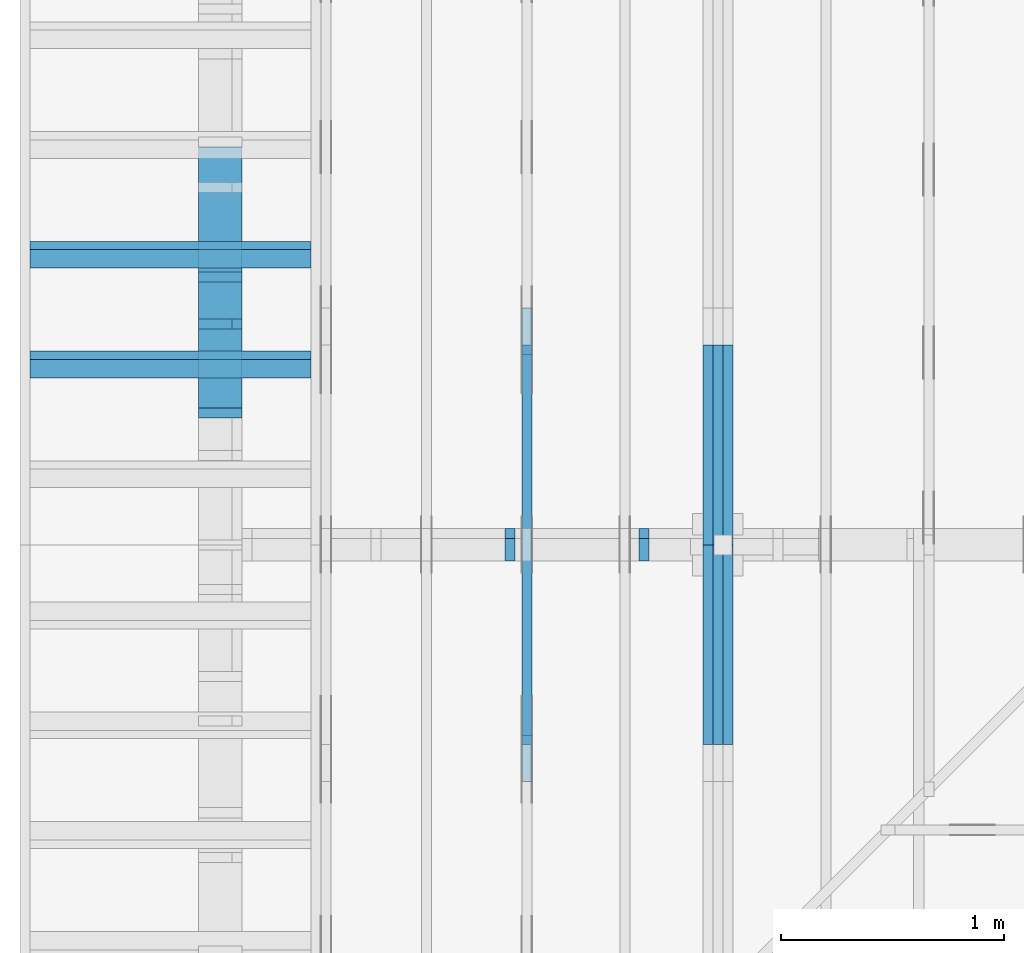
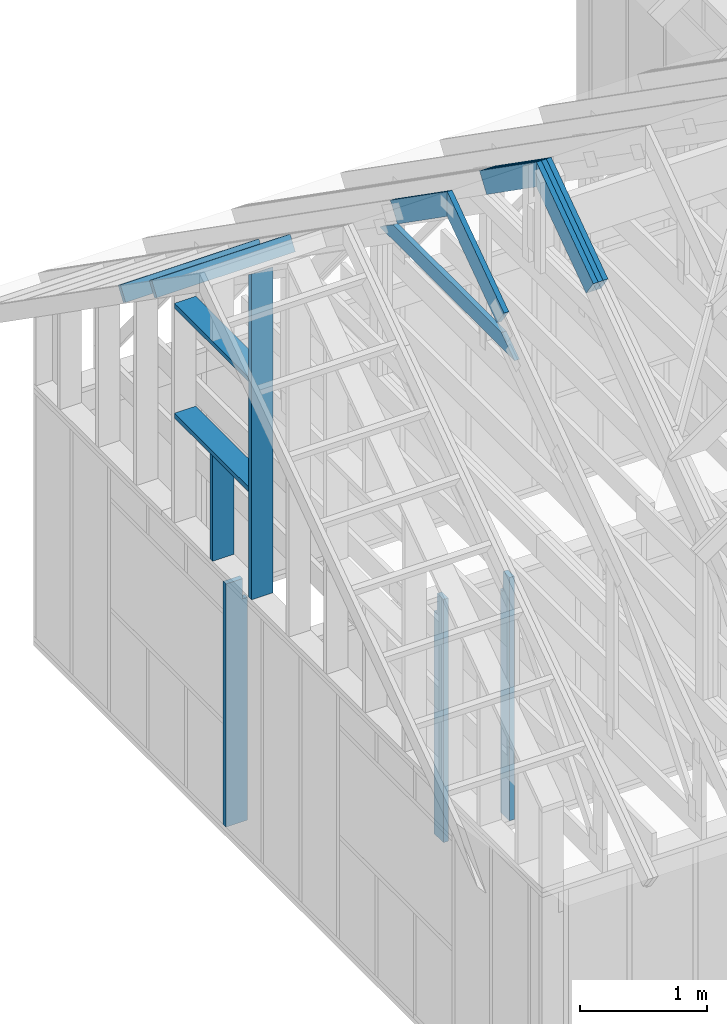
# One storey, part 11 of 70: 18 members, 6 elements without a shape of their own.
"""IFC2X3 building model written with IfcOpenShell, lengths in millimetres."""

from ifc_helpers import new_model, si_unit, frame, origin, origin_with_axes, origin_2d, place, context, project, spatial, faceted_brep, element, aggregate, save


model = new_model("IFC2X3")

# Units and contexts
model_context = context("Model", 3, precision=1e-05, world=origin())
plan_context = context("Plan", 2, precision=1e-05, world=origin_2d())
ifc_project = project(units=[si_unit("LENGTHUNIT", "METRE", prefix="MILLI"), si_unit("AREAUNIT", "SQUARE_METRE"), si_unit("VOLUMEUNIT", "CUBIC_METRE"), si_unit("SOLIDANGLEUNIT", "STERADIAN"), si_unit("PLANEANGLEUNIT", "RADIAN"), si_unit("MASSUNIT", "GRAM"), si_unit("TIMEUNIT", "SECOND"), si_unit("THERMODYNAMICTEMPERATUREUNIT", "DEGREE_CELSIUS"), si_unit("LUMINOUSINTENSITYUNIT", "LUMEN")], contexts=[model_context, plan_context])

# Site, building, storey
site_placement = place(None, origin_with_axes())
site = spatial("IfcSite", under=ifc_project, at=site_placement, CompositionType="ELEMENT")
building_placement = place(site_placement, origin_with_axes())
building = spatial("IfcBuilding", under=site, at=building_placement, Name="Layout 1", CompositionType="ELEMENT")
storey_placement = place(building_placement, origin_with_axes())
storey = spatial("IfcBuildingStorey", under=building, at=storey_placement, Name="Storey 1", CompositionType="ELEMENT", Elevation=0.0)

# Assembly, members
assembly_1_placement = place(storey_placement, frame((1969.9999999999982, 8000.000000000001, 1.1021457184401395e-14), z_axis=(-1.0, 1.836909530733566e-16, 6.123031769111886e-17), x_axis=(-1.836909530733566e-16, -1.0, 0.0)))
assembly_1 = element("IfcElementAssembly", 1, at=assembly_1_placement, inside=storey, Name="T11", AssemblyPlace="FACTORY", PredefinedType="TRUSS")
member_1_placement = place(assembly_1_placement, frame((3217.6903587327556, 3014.9999999980873, -90.0), z_axis=(0.0, 0.0, 1.0), x_axis=(0.8191520442889916, 0.5735764363510464, 0.0)))
member_1 = element("IfcMember", 2, at=member_1_placement, Name="T18", context=model_context, shape_type="Brep", body=[
    faceted_brep([(1091.564200553914, 195.00000000125283, 45.0), (0.0, 195.00000000125283, 45.0), (8.731149137020111e-11, 0.0, 45.0), (955.0237306050312, 0.0, 45.0), (0.0, 195.00000000125283, 0.0), (1091.564200553914, 195.00000000125283, 1.3367364556033665e-13), (955.0237306050312, 0.0, 1.1695281285500715e-13), (8.731149137020111e-11, 0.0, 1.0692220709365594e-26), (8.731149137020111e-11, 0.0, 0.0), (8.731424673449721e-11, 1.2330791498681715e-27, 45.0), (4.7951469120545665e-14, 195.000000002565, 45.0), (4.5196104824445316e-14, 195.000000002565, -2.7673718568020907e-30), (955.0237306050312, 4.127318893216278e-09, -1.955486371747768e-30), (955.0237306050312, 4.127321648580574e-09, 45.0), (8.73114913702011e-11, 2.7553642961032684e-15, 45.0), (8.731149137020111e-11, 2.9197490389586947e-27, -1.78777161234152e-43), (1091.564200553914, 195.00000000125283, 0.0), (1091.564200553914, 195.00000000125283, 45.0), (955.0237306050312, 4.127286956645548e-09, 45.0), (955.0237306050312, 4.127286956645548e-09, 0.0), (0.0, 195.000000002565, 0.0), (0.0, 195.000000002565, 45.0), (1091.564200553914, 195.00000000125272, 45.0), (1091.564200553914, 195.00000000125272, -6.310887241768095e-30)], [[[0, 1, 2, 3]], [[4, 5, 6, 7]], [[8, 9, 10, 11]], [[12, 13, 14, 15]], [[16, 17, 18, 19]], [[20, 21, 22, 23]]]),
])
member_2_placement = place(assembly_1_placement, frame((3217.6903587327556, 3014.9999999980873, -135.0), z_axis=(0.0, 0.0, 1.0), x_axis=(0.8191520442889916, 0.5735764363510464, 0.0)))
member_2 = element("IfcMember", 3, at=member_2_placement, Name="T18", context=model_context, shape_type="Brep", body=[
    faceted_brep([(1091.564200553914, 195.00000000125283, 45.0), (0.0, 195.00000000125283, 45.0), (8.731149137020111e-11, 0.0, 45.0), (955.0237306050312, 0.0, 45.0), (0.0, 195.00000000125283, 0.0), (1091.564200553914, 195.00000000125283, 1.3367364556033665e-13), (955.0237306050312, 0.0, 1.1695281285500715e-13), (8.731149137020111e-11, 0.0, 1.0692220709365594e-26), (8.731149137020111e-11, 0.0, 0.0), (8.731424673449721e-11, 1.2330791498681715e-27, 45.0), (4.7951469120545665e-14, 195.000000002565, 45.0), (4.5196104824445316e-14, 195.000000002565, -2.7673718568020907e-30), (955.0237306050312, 4.127318893216278e-09, -1.955486371747768e-30), (955.0237306050312, 4.127321648580574e-09, 45.0), (8.73114913702011e-11, 2.7553642961032684e-15, 45.0), (8.731149137020111e-11, 2.9197490389586947e-27, -1.78777161234152e-43), (1091.564200553914, 195.00000000125283, 0.0), (1091.564200553914, 195.00000000125283, 45.0), (955.0237306050312, 4.127286956645548e-09, 45.0), (955.0237306050312, 4.127286956645548e-09, 0.0), (0.0, 195.000000002565, 0.0), (0.0, 195.000000002565, 45.0), (1091.564200553914, 195.00000000125272, 45.0), (1091.564200553914, 195.00000000125272, -6.310887241768095e-30)], [[[0, 1, 2, 3]], [[4, 5, 6, 7]], [[8, 9, 10, 11]], [[12, 13, 14, 15]], [[16, 17, 18, 19]], [[20, 21, 22, 23]]]),
])
member_3_placement = place(assembly_1_placement, frame((3217.6903587327556, 3014.9999999980873, -180.0), z_axis=(0.0, 0.0, 1.0), x_axis=(0.8191520442889916, 0.5735764363510464, 0.0)))
member_3 = element("IfcMember", 4, at=member_3_placement, Name="T18", context=model_context, shape_type="Brep", body=[
    faceted_brep([(1091.564200553914, 195.00000000125283, 45.0), (0.0, 195.00000000125283, 45.0), (8.731149137020111e-11, 0.0, 45.0), (955.0237306050312, 0.0, 45.0), (0.0, 195.00000000125283, 0.0), (1091.564200553914, 195.00000000125283, 1.3367364556033665e-13), (955.0237306050312, 0.0, 1.1695281285500715e-13), (8.731149137020111e-11, 0.0, 1.0692220709365594e-26), (8.731149137020111e-11, 0.0, 0.0), (8.731424673449721e-11, 1.2330791498681715e-27, 45.0), (4.7951469120545665e-14, 195.000000002565, 45.0), (4.5196104824445316e-14, 195.000000002565, -2.7673718568020907e-30), (955.0237306050312, 4.127318893216278e-09, -1.955486371747768e-30), (955.0237306050312, 4.127321648580574e-09, 45.0), (8.73114913702011e-11, 2.7553642961032684e-15, 45.0), (8.731149137020111e-11, 2.9197490389586947e-27, -1.78777161234152e-43), (1091.564200553914, 195.00000000125283, 0.0), (1091.564200553914, 195.00000000125283, 45.0), (955.0237306050312, 4.127286956645548e-09, 45.0), (955.0237306050312, 4.127286956645548e-09, 0.0), (0.0, 195.000000002565, 0.0), (0.0, 195.000000002565, 45.0), (1091.564200553914, 195.00000000125272, 45.0), (1091.564200553914, 195.00000000125272, -6.310887241768095e-30)], [[[0, 1, 2, 3]], [[4, 5, 6, 7]], [[8, 9, 10, 11]], [[12, 13, 14, 15]], [[16, 17, 18, 19]], [[20, 21, 22, 23]]]),
])
member_4_placement = place(assembly_1_placement, frame((3888.1525949105694, 3641.0955042035366, -90.00000000000001), z_axis=(0.0, 0.0, 1.0), x_axis=(0.8191520442889916, -0.5735764363510465, 0.0)))
member_4 = element("IfcMember", 5, at=member_4_placement, Name="T18", context=model_context, shape_type="Brep", body=[
    faceted_brep([(1091.5642005560503, 194.99999999996362, 45.0), (0.0, 194.99999999996362, 45.0), (136.5404699520857, 0.0, 45.0), (1091.5642005561149, 0.0, 45.0), (0.0, 194.99999999996362, 0.0), (1091.5642005560503, 194.99999999996362, 1.336736455605983e-13), (1091.5642005561149, 0.0, 1.336736455606062e-13), (136.5404699520857, 0.0, 1.6720832705721752e-14), (136.54046995208566, -4.263256414560601e-14, 3.1554436208840472e-30), (136.54046995208566, -4.263256414560601e-14, 45.0), (1.4210854715202004e-14, 195.00000000170263, 45.0), (1.4210854715202004e-14, 195.00000000170263, -2.3665827156630354e-30), (1091.5642005561149, 2.0525182992035547e-09, 1.2934457505065866e-29), (1091.5642005561149, 2.0525210545678508e-09, 45.0), (136.5404699520857, -2.3668346958466476e-14, 45.0), (136.5404699520857, -2.6423711254566825e-14, 1.6179322346954286e-30), (1091.5642005561149, 194.99999999996362, 3.950615413346827e-27), (1091.5642005561149, 194.99999999996362, 45.0), (1091.5642005561149, 2.052729541901499e-09, 45.0), (1091.5642005561149, 2.052729541901499e-09, 0.0), (0.0, 195.00000000170257, 0.0), (0.0, 195.00000000170257, 45.0), (1091.5642005560503, 194.9999999999637, 45.0), (1091.5642005560503, 194.9999999999637, 6.310887241768095e-30)], [[[0, 1, 2, 3]], [[4, 5, 6, 7]], [[8, 9, 10, 11]], [[12, 13, 14, 15]], [[16, 17, 18, 19]], [[20, 21, 22, 23]]]),
])
member_5_placement = place(assembly_1_placement, frame((3888.1525949105694, 3641.0955042035366, -135.0), z_axis=(0.0, 0.0, 1.0), x_axis=(0.8191520442889916, -0.5735764363510465, 0.0)))
member_5 = element("IfcMember", 6, at=member_5_placement, Name="T18", context=model_context, shape_type="Brep", body=[
    faceted_brep([(1091.5642005560503, 194.99999999996362, 45.0), (0.0, 194.99999999996362, 45.0), (136.5404699520857, 0.0, 45.0), (1091.5642005561149, 0.0, 45.0), (0.0, 194.99999999996362, 0.0), (1091.5642005560503, 194.99999999996362, 1.336736455605983e-13), (1091.5642005561149, 0.0, 1.336736455606062e-13), (136.5404699520857, 0.0, 1.6720832705721752e-14), (136.54046995208566, -4.263256414560601e-14, 3.1554436208840472e-30), (136.54046995208566, -4.263256414560601e-14, 45.0), (1.4210854715202004e-14, 195.00000000170263, 45.0), (1.4210854715202004e-14, 195.00000000170263, -2.3665827156630354e-30), (1091.5642005561149, 2.0525182992035547e-09, 1.2934457505065866e-29), (1091.5642005561149, 2.0525210545678508e-09, 45.0), (136.5404699520857, -2.3668346958466476e-14, 45.0), (136.5404699520857, -2.6423711254566825e-14, 1.6179322346954286e-30), (1091.5642005561149, 194.99999999996362, 3.950615413346827e-27), (1091.5642005561149, 194.99999999996362, 45.0), (1091.5642005561149, 2.052729541901499e-09, 45.0), (1091.5642005561149, 2.052729541901499e-09, 0.0), (0.0, 195.00000000170257, 0.0), (0.0, 195.00000000170257, 45.0), (1091.5642005560503, 194.9999999999637, 45.0), (1091.5642005560503, 194.9999999999637, 6.310887241768095e-30)], [[[0, 1, 2, 3]], [[4, 5, 6, 7]], [[8, 9, 10, 11]], [[12, 13, 14, 15]], [[16, 17, 18, 19]], [[20, 21, 22, 23]]]),
])
member_6_placement = place(assembly_1_placement, frame((3888.1525949105694, 3641.0955042035366, -180.00000000000003), z_axis=(0.0, 0.0, 1.0), x_axis=(0.8191520442889916, -0.5735764363510465, 0.0)))
member_6 = element("IfcMember", 7, at=member_6_placement, Name="T18", context=model_context, shape_type="Brep", body=[
    faceted_brep([(1091.5642005560503, 194.99999999996362, 45.0), (0.0, 194.99999999996362, 45.0), (136.5404699520857, 0.0, 45.0), (1091.5642005561149, 0.0, 45.0), (0.0, 194.99999999996362, 0.0), (1091.5642005560503, 194.99999999996362, 1.336736455605983e-13), (1091.5642005561149, 0.0, 1.336736455606062e-13), (136.5404699520857, 0.0, 1.6720832705721752e-14), (136.54046995208566, -4.263256414560601e-14, 3.1554436208840472e-30), (136.54046995208566, -4.263256414560601e-14, 45.0), (1.4210854715202004e-14, 195.00000000170263, 45.0), (1.4210854715202004e-14, 195.00000000170263, -2.3665827156630354e-30), (1091.5642005561149, 2.0525182992035547e-09, 1.2934457505065866e-29), (1091.5642005561149, 2.0525210545678508e-09, 45.0), (136.5404699520857, -2.3668346958466476e-14, 45.0), (136.5404699520857, -2.6423711254566825e-14, 1.6179322346954286e-30), (1091.5642005561149, 194.99999999996362, 3.950615413346827e-27), (1091.5642005561149, 194.99999999996362, 45.0), (1091.5642005561149, 2.052729541901499e-09, 45.0), (1091.5642005561149, 2.052729541901499e-09, 0.0), (0.0, 195.00000000170257, 0.0), (0.0, 195.00000000170257, 45.0), (1091.5642005560503, 194.9999999999637, 45.0), (1091.5642005560503, 194.9999999999637, 6.310887241768095e-30)], [[[0, 1, 2, 3]], [[4, 5, 6, 7]], [[8, 9, 10, 11]], [[12, 13, 14, 15]], [[16, 17, 18, 19]], [[20, 21, 22, 23]]]),
])
aggregate(assembly_1, [member_1, member_2, member_3, member_4, member_5, member_6])

assembly_2_placement = place(storey_placement, frame((1204.9999999999989, 8000.000000000001, 1.3776821480501744e-15), z_axis=(-1.0, 1.836909530733566e-16, 6.123031769111886e-17), x_axis=(-1.836909530733566e-16, -1.0, 0.0)))
assembly_2 = element("IfcElementAssembly", 8, at=assembly_2_placement, inside=storey, Name="T2", AssemblyPlace="FACTORY", PredefinedType="TRUSS")
member_7_placement = place(assembly_2_placement, frame((3217.690358731264, 3015.0000000002183, -45.00000000000001), z_axis=(0.0, 0.0, 1.0), x_axis=(0.8191520442889918, 0.5735764363510462, 0.0)))
member_7 = element("IfcMember", 9, at=member_7_placement, Name="T18", context=model_context, shape_type="Brep", body=[
    faceted_brep([(1091.564200553914, 194.99999999865213, 45.0), (0.0, 194.99999999865213, 45.0), (1.6370904631912708e-10, 7.557900971733034e-10, 45.0), (955.0237306039635, 7.557900971733034e-10, 45.0), (0.0, 194.99999999865213, 0.0), (1091.564200553914, 194.99999999865213, 1.3367364556033665e-13), (955.0237306039635, 7.557900971733034e-10, 1.169528128548764e-13), (1.6370904631912708e-10, 7.557900971733034e-10, 2.004791383006049e-26), (1.6370904631912732e-10, 7.557900971733033e-10, -1.4349296274686127e-41), (1.6371180168342342e-10, 7.557900971733033e-10, 45.0), (6.660321774678196e-14, 194.99999999996407, 45.0), (6.384785345068161e-14, 194.99999999996407, -3.909424350681179e-30), (955.0237306039635, -1.5956987698560245e-13, 9.770514261762543e-30), (955.0237306039635, -1.568145126895021e-13, 45.0), (1.6370904631912708e-10, 7.557928525375995e-10, 45.0), (1.6370904631912708e-10, 7.557900971733034e-10, 0.0), (1091.564200553914, 194.99999999865213, 0.0), (1091.564200553914, 194.99999999865213, 45.0), (955.0237306039635, -5.684341886080802e-14, 45.0), (955.0237306039635, -5.684341886080802e-14, -6.310887241768095e-30), (0.0, 194.99999999996407, 0.0), (0.0, 194.99999999996407, 45.0), (1091.564200553914, 194.99999999865202, 45.0), (1091.564200553914, 194.99999999865202, -6.310887241768095e-30)], [[[0, 1, 2, 3]], [[4, 5, 6, 7]], [[8, 9, 10, 11]], [[12, 13, 14, 15]], [[16, 17, 18, 19]], [[20, 21, 22, 23]]]),
])
member_8_placement = place(assembly_2_placement, frame((3888.1525949105694, 3641.0955042035366, -45.00000000000001), z_axis=(0.0, 0.0, 1.0), x_axis=(0.8191520442889916, -0.5735764363510465, 0.0)))
member_8 = element("IfcMember", 10, at=member_8_placement, Name="T18", context=model_context, shape_type="Brep", body=[
    faceted_brep([(1091.5642005560503, 194.99999999996362, 45.0), (0.0, 194.99999999996362, 45.0), (136.54046995208614, 0.0, 45.0), (1091.5642005561149, 0.0, 45.0), (0.0, 194.99999999996362, 0.0), (1091.5642005560503, 194.99999999996362, 1.336736455605983e-13), (1091.5642005561149, 0.0, 1.336736455606062e-13), (136.54046995208614, 0.0, 1.6720832705721806e-14), (136.54046995208614, -2.842170943040401e-14, 3.0619884913871384e-31), (136.54046995208614, -2.842170943040401e-14, 45.0), (1.4210854715202004e-14, 195.00000000170263, 45.0), (1.4210854715202004e-14, 195.00000000170263, -5.932810329456638e-31), (1091.5642005561149, 2.0525182992035534e-09, 1.2934457505131873e-29), (1091.5642005561149, 2.0525210545678495e-09, 45.0), (136.54046995208614, -2.3668346958569874e-14, 45.0), (136.54046995208614, -2.6423711254670222e-14, 1.6179322347011683e-30), (1091.5642005561149, 194.99999999996362, 3.950615413346827e-27), (1091.5642005561149, 194.99999999996362, 45.0), (1091.5642005561149, 2.052729541901499e-09, 45.0), (1091.5642005561149, 2.052729541901499e-09, 0.0), (0.0, 195.00000000170257, 0.0), (0.0, 195.00000000170257, 45.0), (1091.5642005560503, 194.9999999999637, 45.0), (1091.5642005560503, 194.9999999999637, 6.310887241768095e-30)], [[[0, 1, 2, 3]], [[4, 5, 6, 7]], [[8, 9, 10, 11]], [[12, 13, 14, 15]], [[16, 17, 18, 19]], [[20, 21, 22, 23]]]),
])
member_9_placement = place(assembly_2_placement, frame((5060.798502586593, 2964.999999998785, -45.0), z_axis=(0.0, 0.0, 1.0), x_axis=(-1.0, 1.2246063538223773e-16, 0.0)))
member_9 = element("IfcMember", 11, at=member_9_placement, Name="C1", context=model_context, shape_type="Brep", body=[
    faceted_brep([(2121.597005175296, 145.00000000000728, 45.0), (0.0, 145.00000000000728, 45.0), (207.08146097743884, 0.0, 45.0), (1914.5155441979737, 0.0, 45.0), (0.0, 145.00000000000728, 0.0), (2121.597005175296, 145.00000000000728, 2.5981211727881944e-13), (1914.5155441979737, 0.0, 2.3445278999165447e-13), (207.08146097743884, 0.0, 2.5359327287179227e-14), (207.08146097743878, -7.105427357601002e-14, 3.1554436208840472e-30), (207.08146097743878, -7.105427357601002e-14, 45.0), (1.4210854715202004e-14, 145.00000000000728, 45.0), (1.4210854715202004e-14, 145.00000000000728, 0.0), (1914.5155441979737, 7.26803319922997e-12, 4.8521444511629875e-31), (1914.5155441979737, 7.27078856352607e-12, 45.0), (207.08146097743884, 1.898228698049977e-15, 45.0), (207.08146097743884, -8.571355980503717e-16, 5.248268497299439e-32), (2121.597005175296, 145.00000000000728, 0.0), (2121.597005175296, 145.00000000000728, 45.0), (1914.515544197974, 7.389644451905042e-12, 45.0), (1914.515544197974, 7.389644451905042e-12, 1.262177448353619e-29), (0.0, 145.00000000000728, 0.0), (-1.6871183120499046e-31, 145.00000000000728, 45.0), (2121.597005175296, 145.00000000000713, 45.0), (2121.597005175296, 145.00000000000713, -7.888609052210118e-30)], [[[0, 1, 2, 3]], [[4, 5, 6, 7]], [[8, 9, 10, 11]], [[12, 13, 14, 15]], [[16, 17, 18, 19]], [[20, 21, 22, 23]]]),
])
aggregate(assembly_2, [member_7, member_8, member_9])

# Assembly, member
assembly_3_placement = place(storey_placement, frame((-243.55339059327574, 8000.000000000001, -2470.0), z_axis=(-1.0, 1.836909530733566e-16, 6.123031769111886e-17), x_axis=(-1.836909530733566e-16, -1.0, 0.0)))
assembly_3 = element("IfcElementAssembly", 12, at=assembly_3_placement, inside=storey, Name="VE3", AssemblyPlace="FACTORY", PredefinedType="NOTDEFINED")
member_10_placement = place(assembly_3_placement, frame((2987.5000000036525, 2425.0, -195.00000000000003), z_axis=(0.0, 0.0, 1.0), x_axis=(-1.836909530733566e-16, -1.0, 0.0)))
member_10 = element("IfcMember", 13, at=member_10_placement, Name="S11", context=model_context, shape_type="Brep", body=[
    faceted_brep([(0.0, 45.0, 45.00000000000003), (195.00000000186265, 45.0, 45.00000000000005), (195.00000000186265, 0.0, 45.00000000000005), (0.0, 0.0, 45.00000000000003), (195.00000000186265, -2.1311460639909362e-46, 2.842170943040401e-14), (195.00000000186265, -3.3742366240998114e-31, 45.00000000000003), (195.00000000186265, 45.0, 45.00000000000003), (195.00000000186265, 45.0, 2.842170943040401e-14), (2.7553642961003504e-15, -3.3742366240998114e-31, 45.00000000000003), (1.193991194976818e-14, -1.4621692037765842e-30, 195.00000000000003), (1.7450640541968876e-14, 45.0, 195.00000000000003), (8.266092888301048e-15, 45.0, 45.00000000000003), (2335.0, -4.2891837542628763e-13, 2.842170943040403e-14), (2335.0, -4.1697846347651946e-13, 195.00000000000003), (2.1932538056648764e-30, 1.193991194976818e-14, 195.00000000000003), (5.061354936149717e-31, 2.7553642961003504e-15, 45.00000000000003), (195.00000000186265, -3.306437155354634e-14, 45.00000000000003), (195.00000000186265, -3.5819735849646686e-14, 2.842170943040401e-14), (-1.6871183120499057e-31, 45.0, 45.00000000000003), (-7.310846018882921e-31, 44.999999999999986, 195.00000000000003), (2335.0, 44.999999999999844, 195.00000000000003), (2335.0, 44.99999999999986, 2.8421709430403998e-14), (195.00000000186265, 44.999999999999986, 2.842170943040401e-14), (195.00000000186265, 44.999999999999986, 45.00000000000003), (2335.0, 45.000000000000455, 0.0), (2335.0, 45.000000000000455, 195.00000000000003), (2335.0, 4.547473508864641e-13, 195.00000000000003), (2335.0, 4.547473508864641e-13, 0.0), (2335.0, 45.000000000000455, 195.00000000000003), (0.0, 45.000000000000455, 195.00000000000003), (0.0, 0.0, 195.00000000000003), (2335.0, 0.0, 195.00000000000003), (195.00000000186265, 45.0, 5.2301533330168465e-14), (2335.0, 45.0, 3.143672930479291e-13), (2335.0, 4.547473508864641e-13, 3.143672930479291e-13), (195.00000000186265, 4.547473508864641e-13, 5.2301533330168465e-14)], [[[0, 1, 2, 3]], [[4, 5, 6, 7]], [[8, 9, 10, 11]], [[12, 13, 14, 15, 16, 17]], [[18, 19, 20, 21, 22, 23]], [[24, 25, 26, 27]], [[28, 29, 30, 31]], [[32, 33, 34, 35]]]),
])
aggregate(assembly_3, [member_10])

# Assembly, members
assembly_4_placement = place(storey_placement, frame((-48.55339059327645, 2.2546681725408788e-11, 1.1939911949768178e-14), z_axis=(1.0, 1.156240088482502e-13, 6.123031769111886e-17), x_axis=(-1.156240088482502e-13, 1.0, 0.0)))
assembly_4 = element("IfcElementAssembly", 14, at=assembly_4_placement, inside=storey, Name="VEg1", AssemblyPlace="FACTORY", PredefinedType="NOTDEFINED")
member_11_placement = place(assembly_4_placement, frame((4567.499999998996, 3171.5152030410027, -195.0), z_axis=(0.0, 0.0, 1.0), x_axis=(-1.836909530733566e-16, -1.0, 0.0)))
member_11 = element("IfcMember", 15, at=member_11_placement, Name="S6", context=model_context, shape_type="Brep", body=[
    faceted_brep([(3126.5152030410027, 45.00000000000091, 195.0), (31.509339219439426, 45.00000000000091, 195.0), (0.0, 0.0, 195.0), (3126.5152030410027, 0.0, 195.0), (31.509339219439426, 45.00000000000091, 3.8586537012870146e-15), (3126.5152030410027, 45.00000000000091, 3.828750382966272e-13), (3126.5152030410027, 0.0, 3.828750382966272e-13), (0.0, 0.0, 0.0), (0.0, 0.0, 0.0), (9.78060328228291e-15, -6.848452146493666e-15, 195.0), (31.509339219439447, 44.99999999999999, 195.0), (31.509339219439436, 45.0, -3.944304526105059e-31), (3126.5152030410027, -5.743125574449408e-13, 9.085398987429847e-29), (3126.5152030410027, -5.623726454951726e-13, 195.0), (2.193253805664876e-30, 1.1939911949768178e-14, 195.0), (0.0, 0.0, 0.0), (3126.5152030410027, 45.00000000000091, 0.0), (3126.5152030410027, 45.00000000000091, 195.0), (3126.5152030410027, 9.094947017729282e-13, 195.0), (3126.5152030410027, 9.094947017729282e-13, 0.0), (31.509339219439426, 45.00000000000001, 3.944304526105059e-31), (31.509339219439426, 44.99999999999999, 195.0), (3126.5152030410027, 45.00000000000118, 195.0), (3126.5152030410027, 45.00000000000119, 1.735493991486226e-29)], [[[0, 1, 2, 3]], [[4, 5, 6, 7]], [[8, 9, 10, 11]], [[12, 13, 14, 15]], [[16, 17, 18, 19]], [[20, 21, 22, 23]]]),
])
member_12_placement = place(assembly_4_placement, frame((5782.499999997181, 2154.999999998792, -195.0), z_axis=(0.0, 0.0, 1.0), x_axis=(-1.0, 1.2246063538223773e-16, 0.0)))
member_12 = element("IfcMember", 16, at=member_12_placement, Name="S26", context=model_context, shape_type="Brep", body=[
    faceted_brep([(1170.0000000000182, 45.00000000002956, 195.0), (0.0, 45.00000000002956, 195.0), (0.0, 0.0, 195.0), (1170.0000000000182, 0.0, 195.0), (0.0, 45.00000000002956, 0.0), (1170.0000000000182, 45.00000000002956, 1.4327894339722036e-13), (1170.0000000000182, 0.0, 1.4327894339722036e-13), (0.0, 0.0, 0.0), (0.0, 0.0, 0.0), (1.1939911949768178e-14, -1.462169203776584e-30, 195.0), (1.7450640541968876e-14, 45.0, 195.0), (5.510728592200698e-15, 45.0, -3.3742366240998092e-31), (1170.0000000000182, 2.992097536532989e-11, -2.2189717589051556e-29), (1170.0000000000182, 2.9932915277279655e-11, 195.0), (-3.0534513787454363e-28, 1.1939911949768178e-14, 195.0), (0.0, 0.0, 0.0), (1170.0000000000182, 45.00000000002956, 0.0), (1170.0000000000182, 45.00000000002956, 195.0), (1170.0000000000182, 2.955857780762017e-11, 195.0), (1170.0000000000182, 2.955857780762017e-11, 0.0), (0.0, 45.0, 0.0), (2.0194839173657902e-28, 44.999999999999986, 195.0), (1170.0000000000182, 45.00000000002953, 195.0), (1170.0000000000182, 45.000000000029544, -1.1832913578315177e-30)], [[[0, 1, 2, 3]], [[4, 5, 6, 7]], [[8, 9, 10, 11]], [[12, 13, 14, 15]], [[16, 17, 18, 19]], [[20, 21, 22, 23]]]),
])
member_13_placement = place(assembly_4_placement, frame((4612.499999997162, 1055.0, -195.0), z_axis=(0.0, 0.0, 1.0), x_axis=(1.0, 0.0, 0.0)))
member_13 = element("IfcMember", 17, at=member_13_placement, Name="S26", context=model_context, shape_type="Brep", body=[
    faceted_brep([(1170.0000000000182, 45.0, 195.0), (0.0, 45.0, 195.0), (0.0, 0.0, 195.0), (1170.0000000000182, 0.0, 195.0), (0.0, 45.0, 0.0), (1170.0000000000182, 45.0, 1.4327894339722036e-13), (1170.0000000000182, 0.0, 1.4327894339722036e-13), (0.0, 0.0, 0.0), (0.0, 0.0, 0.0), (1.1939911949768178e-14, -1.462169203776584e-30, 195.0), (1.7450640541968876e-14, 45.0, 195.0), (5.510728592200698e-15, 45.0, -3.3742366240998092e-31), (1170.0000000000182, -2.1491841509583054e-13, 1.315952283398946e-29), (1170.0000000000182, -2.0297850314606236e-13, 195.0), (2.193253805664876e-30, 1.1939911949768178e-14, 195.0), (0.0, 0.0, 0.0), (1170.0000000000182, 45.0, 0.0), (1170.0000000000182, 45.0, 195.0), (1170.0000000000182, 0.0, 195.0), (1170.0000000000182, 0.0, 0.0), (0.0, 45.0, 0.0), (-7.31084601888292e-31, 44.999999999999986, 195.0), (1170.0000000000182, 44.999999999999915, 195.0), (1170.0000000000182, 44.99999999999993, -4.338734978715565e-30)], [[[0, 1, 2, 3]], [[4, 5, 6, 7]], [[8, 9, 10, 11]], [[12, 13, 14, 15]], [[16, 17, 18, 19]], [[20, 21, 22, 23]]]),
])
member_14_placement = place(assembly_4_placement, frame((5222.499999999389, 45.0, -195.0), z_axis=(0.0, 0.0, 1.0), x_axis=(6.123031769111886e-17, 1.0, 0.0)))
member_14 = element("IfcMember", 18, at=member_14_placement, Name="S31", context=model_context, shape_type="Brep", body=[
    faceted_brep([(1009.9999999999999, 45.0, 195.0), (0.0, 45.0, 195.0), (0.0, 0.0, 195.0), (1009.9999999999999, 0.0, 195.0), (0.0, 45.0, 0.0), (1009.9999999999999, 45.0, 1.2368524173606008e-13), (1009.9999999999999, 0.0, 1.2368524173606008e-13), (0.0, 0.0, 0.0), (0.0, 0.0, 0.0), (1.1939911949768178e-14, -1.462169203776584e-30, 195.0), (1.7450640541968876e-14, 45.0, 195.0), (5.510728592200698e-15, 45.0, -3.3742366240998092e-31), (1009.9999999999999, -1.8552786260409013e-13, 1.135992996780269e-29), (1009.9999999999999, -1.7358795065432195e-13, 195.0), (2.193253805664876e-30, 1.1939911949768178e-14, 195.0), (0.0, 0.0, 0.0), (1009.9999999999999, 45.0, 0.0), (1009.9999999999999, 45.0, 195.0), (1009.9999999999999, 0.0, 195.0), (1009.9999999999999, 0.0, 0.0), (0.0, 45.0, 0.0), (-7.31084601888292e-31, 44.999999999999986, 195.0), (1009.9999999999999, 44.99999999999993, 195.0), (1009.9999999999999, 44.999999999999936, -3.944304526105059e-30)], [[[0, 1, 2, 3]], [[4, 5, 6, 7]], [[8, 9, 10, 11]], [[12, 13, 14, 15]], [[16, 17, 18, 19]], [[20, 21, 22, 23]]]),
])
aggregate(assembly_4, [member_11, member_12, member_13, member_14])

assembly_5_placement = place(storey_placement, frame((-48.55339059327651, 3927.500000000001, -2470.0), z_axis=(0.0, -1.0, 6.123031769111886e-17), x_axis=(1.0, 0.0, 0.0)))
assembly_5 = element("IfcElementAssembly", 19, at=assembly_5_placement, inside=storey, Name="VE8", AssemblyPlace="FACTORY", PredefinedType="NOTDEFINED")
member_15_placement = place(assembly_5_placement, frame((1177.5000000018194, 2425.0, -145.0), z_axis=(0.0, 0.0, 1.0), x_axis=(-1.836909530733566e-16, -1.0, 0.0)))
member_15 = element("IfcMember", 20, at=member_15_placement, Name="S42", context=model_context, shape_type="Brep", body=[
    faceted_brep([(0.0, 45.0000000000141, 45.0), (195.00000000186265, 45.0000000000141, 45.00000000000002), (195.00000000186265, 2.864908310584724e-11, 45.00000000000002), (0.0, 2.864908310584724e-11, 45.0), (195.00000000186265, 2.6147972675971687e-11, 0.0), (195.00000000186265, 2.6147972675971687e-11, 45.0), (195.00000000186265, 45.00000000001296, 45.0), (195.00000000186265, 45.00000000001296, 0.0), (2.7553642961038573e-15, 2.864908310584724e-11, 45.0), (8.878396065215744e-15, 2.864908310584724e-11, 145.0), (1.438912465741466e-14, 45.0000000000141, 145.0), (8.266092888302773e-15, 45.0000000000141, 45.0), (2335.0, 2.8220164730420952e-11, 2.626280839091018e-29), (2335.0, 2.8229043126486164e-11, 145.0), (1.6308810349815745e-30, 2.8657961501912452e-11, 145.0), (5.061354936149714e-31, 2.865183847014334e-11, 45.0), (195.00000000186265, 2.8616018734293693e-11, 45.0), (195.00000000186265, 2.8613263369997592e-11, 2.1932538056856825e-30), (-1.6871183120499046e-31, 45.00000000001296, 45.0), (-5.436270116605248e-31, 45.00000000001295, 145.0), (2335.0, 45.00000000001281, 145.0), (2335.0, 45.00000000001282, -8.67746995743113e-30), (195.00000000186265, 45.000000000012946, -7.888609052210118e-31), (195.00000000186265, 45.000000000012946, 45.0), (2335.0, 45.0, 2.842170943040401e-14), (2335.0, 45.0, 145.0), (2335.0, 0.0, 145.0), (2335.0, 0.0, 0.0), (2335.0, 45.0, 145.0), (0.0, 45.0, 145.0), (0.0, 2.864908310584724e-11, 145.0), (2335.0, 2.864908310584724e-11, 145.0), (195.00000000186265, 45.00000000001296, 2.3879823899764457e-14), (2335.0, 45.00000000001296, 2.859455836175251e-13), (2335.0, 0.0, 2.859455836175251e-13), (195.00000000186265, 0.0, 2.3879823899764457e-14)], [[[0, 1, 2, 3]], [[4, 5, 6, 7]], [[8, 9, 10, 11]], [[12, 13, 14, 15, 16, 17]], [[18, 19, 20, 21, 22, 23]], [[24, 25, 26, 27]], [[28, 29, 30, 31]], [[32, 33, 34, 35]]]),
])
member_16_placement = place(assembly_5_placement, frame((1777.5000000018335, 2425.0, -145.00000000000003), z_axis=(0.0, 0.0, 1.0), x_axis=(-1.836909530733566e-16, -1.0, 0.0)))
member_16 = element("IfcMember", 21, at=member_16_placement, Name="S42", context=model_context, shape_type="Brep", body=[
    faceted_brep([(0.0, 45.00000000001455, 45.00000000000003), (195.00000000186265, 45.00000000001455, 45.00000000000005), (195.00000000186265, 0.0, 45.00000000000005), (0.0, 0.0, 45.00000000000003), (195.00000000186265, -2.1311460639909362e-46, 2.842170943040401e-14), (195.00000000186265, -3.3742366240998114e-31, 45.00000000000003), (195.00000000186265, 45.00000000001205, 45.00000000000003), (195.00000000186265, 45.00000000001205, 2.842170943040401e-14), (2.7553642961003504e-15, -3.3742366240998114e-31, 45.00000000000003), (8.878396065212235e-15, -1.0872540233210496e-30, 145.0), (1.4389124657414716e-14, 45.00000000001455, 145.00000000000003), (8.26609288830283e-15, 45.00000000001455, 45.00000000000003), (2335.0, -4.2891837542628763e-13, 2.842170943040403e-14), (2335.0, -4.200399793610754e-13, 145.00000000000003), (1.6308810349815748e-30, 8.878396065212237e-15, 145.00000000000003), (5.061354936149717e-31, 2.7553642961003504e-15, 45.00000000000003), (195.00000000186265, -3.306437155354634e-14, 45.00000000000003), (195.00000000186265, -3.5819735849646686e-14, 2.842170943040401e-14), (-1.6871183120499057e-31, 45.00000000001205, 45.00000000000003), (-5.436270116605249e-31, 45.000000000012044, 145.00000000000003), (2335.0, 45.0000000000119, 145.00000000000003), (2335.0, 45.00000000001191, 2.8421709430403998e-14), (195.00000000186265, 45.00000000001204, 2.842170943040401e-14), (195.00000000186265, 45.00000000001204, 45.00000000000003), (2335.0, 44.9999999999859, 0.0), (2335.0, 44.9999999999859, 145.00000000000003), (2335.0, 4.547473508864641e-13, 145.00000000000003), (2335.0, 4.547473508864641e-13, 0.0), (2335.0, 44.9999999999859, 145.00000000000003), (0.0, 44.9999999999859, 145.00000000000003), (0.0, 0.0, 145.00000000000003), (2335.0, 0.0, 145.00000000000003), (195.00000000186265, 45.00000000001205, 5.2301533330168465e-14), (2335.0, 45.00000000001205, 3.143672930479291e-13), (2335.0, 4.547473508864641e-13, 3.143672930479291e-13), (195.00000000186265, 4.547473508864641e-13, 5.2301533330168465e-14)], [[[0, 1, 2, 3]], [[4, 5, 6, 7]], [[8, 9, 10, 11]], [[12, 13, 14, 15, 16, 17]], [[18, 19, 20, 21, 22, 23]], [[24, 25, 26, 27]], [[28, 29, 30, 31]], [[32, 33, 34, 35]]]),
])
aggregate(assembly_5, [member_15, member_16])

assembly_6_placement = place(storey_placement, frame((-1043.5533905932762, 8800.000000000002, 439.83396943223045), z_axis=(9.428742447176872e-17, 0.5735764363510464, 0.8191520442889916), x_axis=(-1.153505523095189e-16, -0.8191520442889916, 0.5735764363510464)))
assembly_6 = element("IfcElementAssembly", 22, at=assembly_6_placement, inside=storey, Name="gs1", AssemblyPlace="FACTORY", PredefinedType="TRUSS")
member_17_placement = place(assembly_6_placement, frame((4244.999999998981, 44.99999999999999, -145.0), z_axis=(0.0, 0.0, 1.0), x_axis=(6.123031769111886e-17, 1.0, 0.0)))
member_17 = element("IfcMember", 23, at=member_17_placement, Name="W4", context=model_context, shape_type="Brep", body=[
    faceted_brep([(1258.5533905932764, 45.0, 145.0), (0.0, 45.0, 145.0), (7.105427357601002e-15, 0.0, 145.0), (1258.5533905932764, 0.0, 145.0), (0.0, 45.0, 0.0), (1258.5533905932764, 45.0, 1.5412324787452224e-13), (1258.5533905932764, 0.0, 1.5412324787452224e-13), (7.105427357601002e-15, 0.0, 8.701351488741532e-31), (7.105427357601002e-15, 0.0, 0.0), (1.5983823422813237e-14, -1.0872540233210496e-30, 145.0), (2.1494552015013935e-14, 45.0, 145.0), (1.26161559498017e-14, 45.0, -7.724912368470575e-31), (1258.5533905932764, -2.3118487181178335e-13, 1.4155523146416086e-29), (1258.5533905932764, -2.2230647574657112e-13, 145.0), (7.105427357601003e-15, 8.878396065212234e-15, 145.0), (7.105427357601002e-15, -1.3052027233112297e-30, 7.991797739966011e-47), (1258.5533905932764, 45.0, 0.0), (1258.5533905932764, 45.0, 145.0), (1258.5533905932764, 0.0, 145.0), (1258.5533905932764, 0.0, 0.0), (0.0, 45.0, 0.0), (-5.436270116605248e-31, 44.99999999999999, 145.0), (1258.5533905932764, 44.999999999999915, 145.0), (1258.5533905932764, 44.99999999999992, -4.733165431326071e-30)], [[[0, 1, 2, 3]], [[4, 5, 6, 7]], [[8, 9, 10, 11]], [[12, 13, 14, 15]], [[16, 17, 18, 19]], [[20, 21, 22, 23]]]),
])
member_18_placement = place(assembly_6_placement, frame((4844.999999998981, 44.99999999999999, -145.0), z_axis=(0.0, 0.0, 1.0), x_axis=(6.123031769111886e-17, 1.0, 0.0)))
member_18 = element("IfcMember", 24, at=member_18_placement, Name="W4", context=model_context, shape_type="Brep", body=[
    faceted_brep([(1258.5533905932764, 44.99999999998545, 145.0), (0.0, 44.99999999998545, 145.0), (7.105427357601002e-15, 0.0, 145.0), (1258.5533905932764, 0.0, 145.0), (0.0, 44.99999999998545, 0.0), (1258.5533905932764, 44.99999999998545, 1.5412324787452224e-13), (1258.5533905932764, 0.0, 1.5412324787452224e-13), (7.105427357601002e-15, 0.0, 8.701351488741532e-31), (7.105427357601002e-15, 0.0, 0.0), (1.5983823422813237e-14, -1.0872540233210496e-30, 145.0), (2.1494552015013935e-14, 45.0, 145.0), (1.26161559498017e-14, 45.0, -7.724912368470575e-31), (1258.5533905932764, -2.3118487181178335e-13, 1.4155523146416086e-29), (1258.5533905932764, -2.2230647574657112e-13, 145.0), (7.105427357601003e-15, 8.878396065212234e-15, 145.0), (7.105427357601002e-15, -1.3052027233112297e-30, 7.991797739966011e-47), (1258.5533905932764, 44.99999999998545, 0.0), (1258.5533905932764, 44.99999999998545, 145.0), (1258.5533905932764, 0.0, 145.0), (1258.5533905932764, 0.0, 0.0), (0.0, 45.0, 0.0), (-1.0097419586828951e-28, 44.99999999999999, 145.0), (1258.5533905932764, 44.999999999985384, 145.0), (1258.5533905932764, 44.99999999998539, -3.549874073494553e-30)], [[[0, 1, 2, 3]], [[4, 5, 6, 7]], [[8, 9, 10, 11]], [[12, 13, 14, 15]], [[16, 17, 18, 19]], [[20, 21, 22, 23]]]),
])
aggregate(assembly_6, [member_17, member_18])

save(model, "model.ifc")
